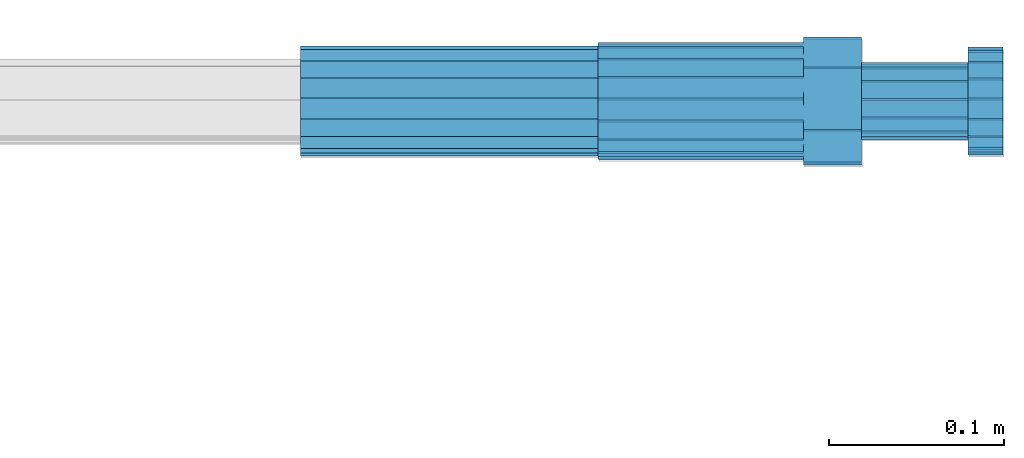
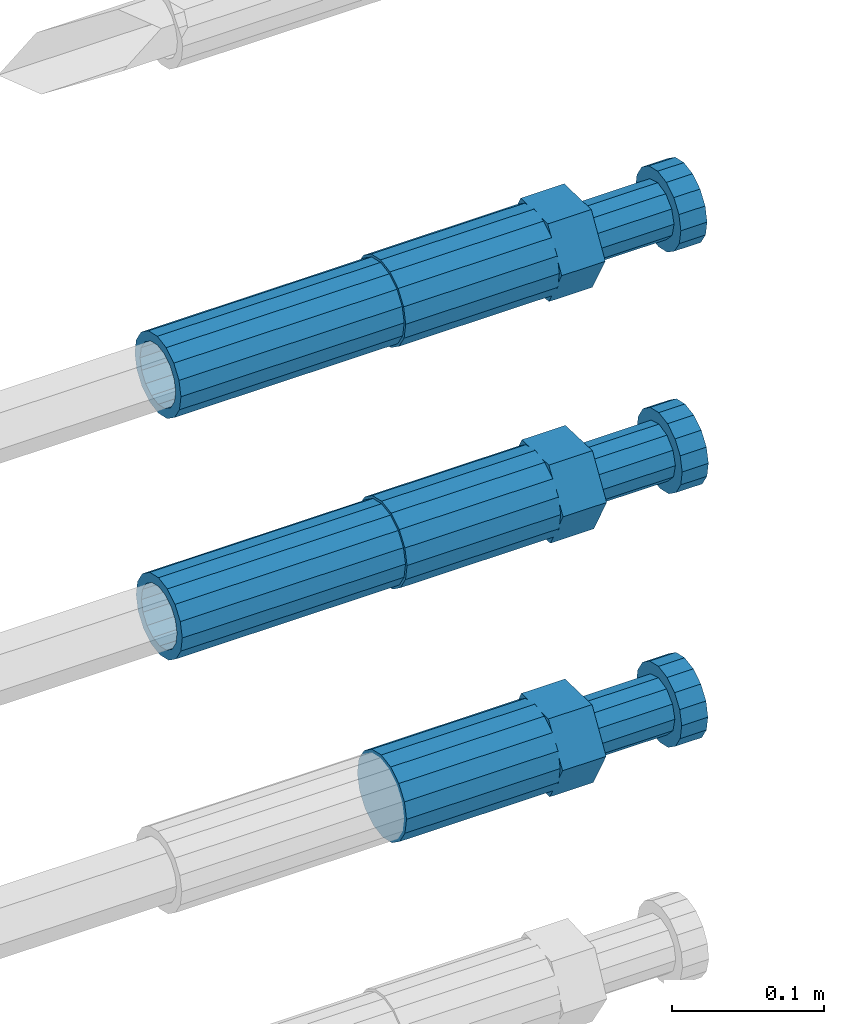
# One storey, part 110 of 177: 5 beams.
"""IFC2X3 building model written with IfcOpenShell, lengths in millimetres."""

from ifc_helpers import new_model, si_unit, frame, origin_with_axes, place, context, subcontext, project, spatial, faceted_brep, material, type_object, element, save


model = new_model("IFC2X3")

# Units and contexts
model_context_1 = context("Model", 3, precision=1e-05, world=origin_with_axes())
model_context_2 = context("Model", 3, precision=1e-05, world=origin_with_axes())
body_context = subcontext(model_context_2, "Body", "Model", "MODEL_VIEW")
ifc_project = project(units=[si_unit("LENGTHUNIT", "METRE", prefix="MILLI"), si_unit("AREAUNIT", "SQUARE_METRE"), si_unit("VOLUMEUNIT", "CUBIC_METRE"), si_unit("MASSUNIT", "GRAM", prefix="KILO"), si_unit("TIMEUNIT", "SECOND"), si_unit("PLANEANGLEUNIT", "RADIAN"), si_unit("SOLIDANGLEUNIT", "STERADIAN"), si_unit("THERMODYNAMICTEMPERATUREUNIT", "DEGREE_CELSIUS"), si_unit("LUMINOUSINTENSITYUNIT", "LUMEN")], contexts=[model_context_1])

# Site, building, storey
site_placement = place(None, origin_with_axes())
site = spatial("IfcSite", under=ifc_project, at=site_placement, CompositionType="ELEMENT")
building_placement = place(site_placement, origin_with_axes())
building = spatial("IfcBuilding", under=site, at=building_placement, Name="Undefined", CompositionType="ELEMENT")
storey_placement = place(building_placement, origin_with_axes())
storey = spatial("IfcBuildingStorey", under=building, at=storey_placement, Name="Undefined", CompositionType="ELEMENT", Elevation=0.0)

# Beams
ifc_material = material(Name="STEEL/S275")
beam_type_1 = type_object("IfcBeamType", PredefinedType="NOTDEFINED")
beam_1_placement = place(storey_placement, frame((2039349.01982224, 6206398.98702464, 20268.9865982332), z_axis=(0.0, -0.0326318619986999, -0.999467438980629), x_axis=(1.0, 0.0, 0.0)))
element("IfcBeam", 1, at=beam_1_placement, inside=storey, type_object=beam_type_1, material=ifc_material, Name="AG40N", context=body_context, shape_type="Brep", body=[
    faceted_brep([(0.0, -23.5000000001164, -9.31322574615479e-10), (0.0, -21.7111690140155, 8.99306066054851), (170.0, -21.7111690140155, 8.99306066054851), (170.0, -23.5, 0.0), (0.0, -16.6170093578839, 16.6170093575493), (170.0, -16.6170093578839, 16.6170093575493), (0.0, -8.99306066057943, 21.7111690137535), (170.0, -8.99306066057943, 21.7111690137535), (0.0, 1.16415321826935e-10, 23.5), (170.0, 0.0, 23.5), (0.0, 8.99306066057943, 21.7111690137535), (170.0, 8.99306066057943, 21.7111690137535), (0.0, 16.6170093578839, 16.6170093575493), (170.0, 16.6170093578839, 16.6170093575493), (0.0, 21.7111690140155, 8.99306066054851), (170.0, 21.7111690140155, 8.99306066054851), (0.0, 23.5000000001164, -9.31322574615479e-10), (170.0, 23.5, 0.0), (0.0, 21.7111690140155, -8.99306066054851), (170.0, 21.7111690140155, -8.99306066054851), (0.0, 16.6170093578839, -16.6170093575493), (170.0, 16.6170093578839, -16.6170093575493), (0.0, 8.99306066057943, -21.7111690137535), (170.0, 8.99306066057943, -21.7111690137535), (0.0, 1.16415321826935e-10, -23.5000000009313), (170.0, 0.0, -23.5), (0.0, -8.99306066057943, -21.7111690137535), (170.0, -8.99306066057943, -21.7111690137535), (0.0, -16.6170093578839, -16.6170093575493), (170.0, -16.6170093578839, -16.6170093575493), (0.0, -21.7111690140155, -8.99306066054851), (170.0, -21.7111690140155, -8.99306066054851), (0.0, -30.5, 0.0), (0.0, -28.1783257415937, -11.6718446873128), (170.0, -28.1783257415937, -11.6718446873128), (170.0, -30.5, 0.0), (0.0, -21.5667568261888, -21.5667568258941), (170.0, -21.5667568261888, -21.5667568258941), (0.0, -11.6718446871346, -28.1783257415518), (170.0, -11.6718446871346, -28.1783257415518), (0.0, 0.0, -30.5), (170.0, 0.0, -30.5), (0.0, 11.6718446871346, -28.1783257415518), (170.0, 11.6718446871346, -28.1783257415518), (0.0, 21.5667568261888, -21.5667568258941), (170.0, 21.5667568261888, -21.5667568258941), (0.0, 28.1783257415937, -11.6718446873128), (170.0, 28.1783257415937, -11.6718446873128), (0.0, 30.5, 0.0), (170.0, 30.5, 0.0), (0.0, 28.1783257415937, 11.6718446873128), (170.0, 28.1783257415937, 11.6718446873128), (0.0, 21.5667568261888, 21.5667568258941), (170.0, 21.5667568261888, 21.5667568258941), (0.0, 11.6718446871346, 28.1783257415518), (170.0, 11.6718446871346, 28.1783257415518), (0.0, 0.0, 30.5), (170.0, 0.0, 30.5), (0.0, -11.6718446871346, 28.1783257415518), (170.0, -11.6718446871346, 28.1783257415518), (0.0, -21.5667568261888, 21.5667568258941), (170.0, -21.5667568261888, 21.5667568258941), (0.0, -28.1783257415937, 11.6718446873128), (170.0, -28.1783257415937, 11.6718446873128)], [[[0, 1, 2, 3]], [[1, 4, 5, 2]], [[4, 6, 7, 5]], [[6, 8, 9, 7]], [[8, 10, 11, 9]], [[10, 12, 13, 11]], [[12, 14, 15, 13]], [[14, 16, 17, 15]], [[16, 18, 19, 17]], [[18, 20, 21, 19]], [[20, 22, 23, 21]], [[22, 24, 25, 23]], [[24, 26, 27, 25]], [[26, 28, 29, 27]], [[28, 30, 31, 29]], [[30, 0, 3, 31]], [[32, 33, 34, 35]], [[33, 36, 37, 34]], [[36, 38, 39, 37]], [[38, 40, 41, 39]], [[40, 42, 43, 41]], [[42, 44, 45, 43]], [[44, 46, 47, 45]], [[46, 48, 49, 47]], [[48, 50, 51, 49]], [[50, 52, 53, 51]], [[52, 54, 55, 53]], [[54, 56, 57, 55]], [[56, 58, 59, 57]], [[58, 60, 61, 59]], [[60, 62, 63, 61]], [[62, 32, 35, 63]], [[37, 39, 41, 43, 45, 47, 49, 51, 53, 55, 57, 59, 61, 63, 35, 34], [5, 7, 9, 11, 13, 15, 17, 19, 21, 23, 25, 27, 29, 31, 3, 2]], [[62, 60, 58, 56, 54, 52, 50, 48, 46, 44, 42, 40, 38, 36, 33, 32], [30, 28, 26, 24, 22, 20, 18, 16, 14, 12, 10, 8, 6, 4, 1, 0]]]),
])
beam_2_placement = place(storey_placement, frame((2039349.01982224, 6206400.75643557, 20462.4006247646), z_axis=(0.0, -0.0239087310098113, -0.999714145434334), x_axis=(1.0, 0.0, 0.0)))
element("IfcBeam", 2, at=beam_2_placement, inside=storey, type_object=beam_type_1, material=ifc_material, Name="AG40N", context=body_context, shape_type="Brep", body=[
    faceted_brep([(0.0, -23.5000000001164, -9.31322574615479e-10), (0.0, -21.7111690140155, 8.99306066054851), (170.0, -21.7111690140155, 8.99306066054851), (170.0, -23.5, 0.0), (0.0, -16.6170093578839, 16.6170093575493), (170.0, -16.6170093578839, 16.6170093575493), (0.0, -8.99306066057943, 21.7111690137535), (170.0, -8.99306066057943, 21.7111690137535), (0.0, 1.16415321826935e-10, 23.5), (170.0, 0.0, 23.5), (0.0, 8.99306066057943, 21.7111690137535), (170.0, 8.99306066057943, 21.7111690137535), (0.0, 16.6170093578839, 16.6170093575493), (170.0, 16.6170093578839, 16.6170093575493), (0.0, 21.7111690140155, 8.99306066054851), (170.0, 21.7111690140155, 8.99306066054851), (0.0, 23.5000000001164, -9.31322574615479e-10), (170.0, 23.5, 0.0), (0.0, 21.7111690140155, -8.99306066054851), (170.0, 21.7111690140155, -8.99306066054851), (0.0, 16.6170093578839, -16.6170093575493), (170.0, 16.6170093578839, -16.6170093575493), (0.0, 8.99306066057943, -21.7111690137535), (170.0, 8.99306066057943, -21.7111690137535), (0.0, 1.16415321826935e-10, -23.5000000009313), (170.0, 0.0, -23.5), (0.0, -8.99306066057943, -21.7111690137535), (170.0, -8.99306066057943, -21.7111690137535), (0.0, -16.6170093578839, -16.6170093575493), (170.0, -16.6170093578839, -16.6170093575493), (0.0, -21.7111690140155, -8.99306066054851), (170.0, -21.7111690140155, -8.99306066054851), (0.0, -30.5, 0.0), (0.0, -28.1783257415937, -11.6718446873128), (170.0, -28.1783257415937, -11.6718446873128), (170.0, -30.5, 0.0), (0.0, -21.5667568261888, -21.5667568258941), (170.0, -21.5667568261888, -21.5667568258941), (0.0, -11.6718446871346, -28.1783257415518), (170.0, -11.6718446871346, -28.1783257415518), (0.0, 0.0, -30.5), (170.0, 0.0, -30.5), (0.0, 11.6718446871346, -28.1783257415518), (170.0, 11.6718446871346, -28.1783257415518), (0.0, 21.5667568261888, -21.5667568258941), (170.0, 21.5667568261888, -21.5667568258941), (0.0, 28.1783257415937, -11.6718446873128), (170.0, 28.1783257415937, -11.6718446873128), (0.0, 30.5, 0.0), (170.0, 30.5, 0.0), (0.0, 28.1783257415937, 11.6718446873128), (170.0, 28.1783257415937, 11.6718446873128), (0.0, 21.5667568261888, 21.5667568258941), (170.0, 21.5667568261888, 21.5667568258941), (0.0, 11.6718446871346, 28.1783257415518), (170.0, 11.6718446871346, 28.1783257415518), (0.0, 0.0, 30.5), (170.0, 0.0, 30.5), (0.0, -11.6718446871346, 28.1783257415518), (170.0, -11.6718446871346, 28.1783257415518), (0.0, -21.5667568261888, 21.5667568258941), (170.0, -21.5667568261888, 21.5667568258941), (0.0, -28.1783257415937, 11.6718446873128), (170.0, -28.1783257415937, 11.6718446873128)], [[[0, 1, 2, 3]], [[1, 4, 5, 2]], [[4, 6, 7, 5]], [[6, 8, 9, 7]], [[8, 10, 11, 9]], [[10, 12, 13, 11]], [[12, 14, 15, 13]], [[14, 16, 17, 15]], [[16, 18, 19, 17]], [[18, 20, 21, 19]], [[20, 22, 23, 21]], [[22, 24, 25, 23]], [[24, 26, 27, 25]], [[26, 28, 29, 27]], [[28, 30, 31, 29]], [[30, 0, 3, 31]], [[32, 33, 34, 35]], [[33, 36, 37, 34]], [[36, 38, 39, 37]], [[38, 40, 41, 39]], [[40, 42, 43, 41]], [[42, 44, 45, 43]], [[44, 46, 47, 45]], [[46, 48, 49, 47]], [[48, 50, 51, 49]], [[50, 52, 53, 51]], [[52, 54, 55, 53]], [[54, 56, 57, 55]], [[56, 58, 59, 57]], [[58, 60, 61, 59]], [[60, 62, 63, 61]], [[62, 32, 35, 63]], [[37, 39, 41, 43, 45, 47, 49, 51, 53, 55, 57, 59, 61, 63, 35, 34], [5, 7, 9, 11, 13, 15, 17, 19, 21, 23, 25, 27, 29, 31, 3, 2]], [[62, 60, 58, 56, 54, 52, 50, 48, 46, 44, 42, 40, 38, 36, 33, 32], [30, 28, 26, 24, 22, 20, 18, 16, 14, 12, 10, 8, 6, 4, 1, 0]]]),
])
beam_type_2 = type_object("IfcBeamType", Name="ROD65", PredefinedType="NOTDEFINED")
beam_3_placement = place(storey_placement, frame((2039519.01982224, 6206399.65861379, 20064.378419571), z_axis=(0.0, -0.0273982399934902, -0.999624597759208), x_axis=(1.0, 0.0, 0.0)))
element("IfcBeam", 3, at=beam_3_placement, inside=storey, type_object=beam_type_2, material=ifc_material, Name="AGB40", ObjectType="ROD65", context=body_context, shape_type="Brep", body=[
    faceted_brep([(117.0, 8.17543110251427, 30.873805644922), (117.0, 17.8250000001863, 30.873805644922), (117.0, 22.0056958701462, 23.6326279877685), (117.0, 12.4372115517035, 30.0260848065373), (117.0, -17.8250000001863, 30.873805644922), (150.200000000186, -17.8250000001863, 30.873805644922), (150.200000000186, 17.8250000001863, 30.873805644922), (117.0, -8.17543110251427, 30.873805644922), (117.0, -12.4372115517035, 30.0260848065373), (117.0, -22.0056958701462, 23.6326279877685), (117.0, -35.6500000003725, 0.0), (150.200000000186, -35.6500000003725, 0.0), (117.0, -30.8443150008097, 8.32369058486074), (117.0, -32.5, 0.0), (117.0, -30.8443150008097, -8.32369058462791), (117.0, -17.8250000001863, -30.873805644922), (150.200000000186, -17.8250000001863, -30.873805644922), (117.0, -22.0056958701462, -23.6326279877685), (117.0, -12.4372115517035, -30.0260848065373), (117.0, -8.17543110251427, -30.873805644922), (117.0, 17.8250000001863, -30.873805644922), (150.200000000186, 17.8250000001863, -30.873805644922), (117.0, 8.17543110251427, -30.873805644922), (117.0, 22.0056958701462, -23.6326279877685), (117.0, 12.4372115517035, -30.0260848065373), (117.0, 35.6500000003725, 0.0), (150.200000000186, 35.6500000003725, 0.0), (117.0, 30.8443150008097, -8.32369058486074), (117.0, 30.8443150008097, 8.32369058462791), (117.0, 32.5, 0.0), (0.0, -22.9809703892097, 22.9809703885621), (0.0, -30.0260848058388, 12.4372115518636), (117.0, -30.0260848067701, 12.4372115519363), (117.0, -22.9809703882784, 22.9809703885112), (-2.3283064365387e-10, 22.9809703892097, -22.9809703885639), (-4.65661287307739e-10, 30.0260848077014, -12.4372115518672), (117.0, 30.0260848067701, -12.4372115519363), (117.0, 22.9809703882784, -22.9809703885112), (-2.3283064365387e-10, -30.0260848067701, -12.4372115518672), (-2.3283064365387e-10, -22.9809703892097, -22.9809703885621), (117.0, -22.9809703882784, -22.9809703885112), (117.0, -30.0260848067701, -12.4372115519363), (-2.3283064365387e-10, -12.4372115507722, 30.0260848066137), (-2.3283064365387e-10, 9.31322574615479e-10, 32.4999999999982), (-2.3283064365387e-10, 12.4372115526348, 30.0260848066137), (0.0, 22.9809703892097, 22.9809703885621), (-2.3283064365387e-10, 30.0260848077014, 12.4372115518636), (-2.3283064365387e-10, 32.5, 0.0), (-2.3283064365387e-10, 12.4372115526348, -30.0260848066173), (-2.3283064365387e-10, 9.31322574615479e-10, -32.5), (-2.3283064365387e-10, -12.4372115517035, -30.0260848066173), (-4.65661287307739e-10, -32.4999999990687, -1.81898940354586e-12), (117.0, 22.9809703882784, 22.9809703885112), (117.0, 30.0260848067701, 12.4372115519363), (117.0, 0.0, -32.5), (117.0, 0.0, 32.5), (150.200000000186, 10.5, -18.1865334794857), (150.200000000186, 0.0, -21.0), (150.200000000186, -10.5, -18.1865334794857), (150.200000000186, -18.18653347902, -10.5), (150.200000000186, -21.0, 0.0), (150.200000000186, -18.18653347902, 10.5), (150.200000000186, -10.5, 18.1865334794857), (150.200000000186, 0.0, 21.0), (150.200000000186, 10.5, 18.1865334794857), (150.200000000186, 18.18653347902, 10.5), (150.200000000186, 21.0, 0.0), (150.200000000186, 18.18653347902, -10.5), (210.980000000447, -18.18653347902, 10.5), (210.980000000447, -21.0, 0.0), (210.980000000447, -10.5, 18.1865334794857), (210.980000000447, 0.0, 21.0), (210.980000000447, 10.5, 18.1865334794857), (210.980000000447, 18.18653347902, 10.5), (210.980000000447, 21.0, 0.0), (210.980000000447, 18.18653347902, -10.5), (210.980000000447, 10.5, -18.1865334794857), (210.980000000447, 0.0, -21.0), (210.980000000447, -10.5, -18.1865334794857), (210.980000000447, -18.18653347902, -10.5), (211.001368442696, -27.7269937992096, -11.491116326768), (211.003082550167, -21.2238094303757, -21.223815418547), (231.002518367059, -21.2131944671273, -21.2132004550658), (231.000804259587, -27.7163788359612, -11.4805013632867), (211.001368440451, -11.4911085031927, -27.7269970395137), (231.000804257343, -11.4804935399443, -27.7163820760325), (210.996487071217, -0.0106065049767494, -30.0106107392348), (230.995922888109, 8.45827162265778e-06, -29.9999957757536), (210.989181586672, 11.46989420522, -27.7269970329944), (230.988617403564, 11.4805091684684, -27.7163820695132), (210.980564180623, 21.2025914648548, -21.2238154064398), (230.979999997515, 21.2132064281031, -21.2132004429586), (210.971946775022, 27.7057703435421, -11.4911163107026), (230.971382591913, 27.7163853067905, -11.4805013472214), (210.96464129175, 29.9893808094785, -0.0106149562634528), (230.964077108642, 29.9999957727268, 7.21774995326996e-09), (210.959759924415, 27.7057638689876, 11.4698863970116), (230.959195741307, 27.7163788322359, 11.4805013604928), (210.958045816944, 21.2025795001537, 21.2025854887906), (230.957481633835, 21.213194463402, 21.2132004522718), (210.95975992666, 11.4698785729706, 27.7057671097573), (230.959195743551, 11.480493536219, 27.7163820732385), (210.964641295894, -0.010623425245285, 29.9893808094785), (230.964077112785, -8.46199691295624e-06, 29.9999957729597), (210.971946780439, -11.4911241354421, 27.705767103238), (230.97138259733, -11.4805091721937, 27.7163820667192), (210.980564186488, -21.2238213950768, 21.2025854766835), (230.980000003379, -21.2132064318284, 21.2132004401647), (210.989181592089, -27.7270002737641, 11.4698863809463), (230.988617408981, -27.7163853105158, 11.4805013444275), (210.996487075361, -30.0106107397005, -0.0106149734929204), (230.995922892253, -29.9999957764521, -1.00117176771164e-08)], [[[0, 1, 2, 3]], [[4, 5, 6, 1, 0, 7]], [[4, 7, 8, 9]], [[10, 11, 5, 4, 9, 12]], [[10, 12, 13, 14]], [[15, 16, 11, 10, 14, 17]], [[15, 17, 18, 19]], [[20, 21, 16, 15, 19, 22]], [[23, 20, 22, 24]], [[25, 26, 21, 20, 23, 27]], [[28, 25, 27, 29]], [[30, 31, 32, 33]], [[34, 35, 36, 37]], [[38, 39, 40, 41]], [[31, 30, 42, 43, 44, 45, 46, 47, 35, 34, 48, 49, 50, 39, 38, 51]], [[46, 45, 52, 53]], [[29, 47, 46, 53, 28]], [[27, 36, 35, 47, 29]], [[23, 37, 36, 27]], [[24, 48, 34, 37, 23]], [[22, 54, 49, 48, 24]], [[19, 54, 22]], [[18, 50, 49, 54, 19]], [[17, 40, 39, 50, 18]], [[14, 41, 40, 17]], [[13, 51, 38, 41, 14]], [[12, 32, 31, 51, 13]], [[9, 33, 32, 12]], [[8, 42, 30, 33, 9]], [[7, 55, 43, 42, 8]], [[0, 55, 7]], [[3, 44, 43, 55, 0]], [[2, 52, 45, 44, 3]], [[28, 53, 52, 2]], [[1, 6, 26, 25, 28, 2]], [[5, 11, 16, 21, 26, 6], [56, 57, 58, 59, 60, 61, 62, 63, 64, 65, 66, 67]], [[68, 61, 60, 69]], [[70, 62, 61, 68]], [[71, 63, 62, 70]], [[72, 64, 63, 71]], [[73, 65, 64, 72]], [[74, 66, 65, 73]], [[75, 67, 66, 74]], [[76, 56, 67, 75]], [[77, 57, 56, 76]], [[78, 58, 57, 77]], [[79, 59, 58, 78]], [[69, 60, 59, 79]], [[80, 81, 82, 83]], [[81, 84, 85, 82]], [[84, 86, 87, 85]], [[86, 88, 89, 87]], [[88, 90, 91, 89]], [[90, 92, 93, 91]], [[92, 94, 95, 93]], [[94, 96, 97, 95]], [[96, 98, 99, 97]], [[98, 100, 101, 99]], [[100, 102, 103, 101]], [[102, 104, 105, 103]], [[104, 106, 107, 105]], [[106, 108, 109, 107]], [[108, 110, 111, 109]], [[82, 85, 87, 89, 91, 93, 95, 97, 99, 101, 103, 105, 107, 109, 111, 83]], [[110, 80, 83, 111]], [[108, 106, 104, 102, 100, 98, 96, 94, 92, 90, 88, 86, 84, 81, 80, 110], [75, 74, 73, 72, 71, 70, 68, 69, 79, 78, 77, 76]]]),
])
beam_4_placement = place(storey_placement, frame((2039519.01982224, 6206398.9870246, 20268.9865982313), z_axis=(0.0, -0.0326318619986999, -0.999467438980629), x_axis=(1.0, 0.0, 0.0)))
element("IfcBeam", 4, at=beam_4_placement, inside=storey, type_object=beam_type_2, material=ifc_material, Name="AGB40", ObjectType="ROD65", context=body_context, shape_type="Brep", body=[
    faceted_brep([(117.0, 8.17543110251427, 30.873805644922), (117.0, 17.8250000001863, 30.873805644922), (117.0, 22.0056958701462, 23.6326279877685), (117.0, 12.4372115517035, 30.0260848065373), (117.0, -17.8250000001863, 30.873805644922), (150.200000000186, -17.8250000001863, 30.873805644922), (150.200000000186, 17.8250000001863, 30.873805644922), (117.0, -8.17543110251427, 30.873805644922), (117.0, -12.4372115517035, 30.0260848065373), (117.0, -22.0056958701462, 23.6326279877685), (117.0, -35.6500000003725, 0.0), (150.200000000186, -35.6500000003725, 0.0), (117.0, -30.8443150008097, 8.32369058486074), (117.0, -32.5, 0.0), (117.0, -30.8443150008097, -8.32369058462791), (117.0, -17.8250000001863, -30.873805644922), (150.200000000186, -17.8250000001863, -30.873805644922), (117.0, -22.0056958701462, -23.6326279877685), (117.0, -12.4372115517035, -30.0260848065373), (117.0, -8.17543110251427, -30.873805644922), (117.0, 17.8250000001863, -30.873805644922), (150.200000000186, 17.8250000001863, -30.873805644922), (117.0, 8.17543110251427, -30.873805644922), (117.0, 22.0056958701462, -23.6326279877685), (117.0, 12.4372115517035, -30.0260848065373), (117.0, 35.6500000003725, 0.0), (150.200000000186, 35.6500000003725, 0.0), (117.0, 30.8443150008097, -8.32369058486074), (117.0, 30.8443150008097, 8.32369058462791), (117.0, 32.5, 0.0), (0.0, -22.9809703892097, 22.9809703885621), (0.0, -30.0260848058388, 12.4372115518636), (117.0, -30.0260848067701, 12.4372115519363), (117.0, -22.9809703882784, 22.9809703885112), (-2.3283064365387e-10, 22.9809703892097, -22.9809703885639), (-4.65661287307739e-10, 30.0260848077014, -12.4372115518672), (117.0, 30.0260848067701, -12.4372115519363), (117.0, 22.9809703882784, -22.9809703885112), (-2.3283064365387e-10, -30.0260848067701, -12.4372115518672), (-2.3283064365387e-10, -22.9809703892097, -22.9809703885621), (117.0, -22.9809703882784, -22.9809703885112), (117.0, -30.0260848067701, -12.4372115519363), (-2.3283064365387e-10, -12.4372115507722, 30.0260848066137), (-2.3283064365387e-10, 9.31322574615479e-10, 32.4999999999982), (-2.3283064365387e-10, 12.4372115526348, 30.0260848066137), (0.0, 22.9809703892097, 22.9809703885621), (-2.3283064365387e-10, 30.0260848077014, 12.4372115518636), (-2.3283064365387e-10, 32.5, 0.0), (-2.3283064365387e-10, 12.4372115526348, -30.0260848066173), (-2.3283064365387e-10, 9.31322574615479e-10, -32.5), (-2.3283064365387e-10, -12.4372115517035, -30.0260848066173), (-4.65661287307739e-10, -32.4999999990687, -1.81898940354586e-12), (117.0, 22.9809703882784, 22.9809703885112), (117.0, 30.0260848067701, 12.4372115519363), (117.0, 0.0, -32.5), (117.0, 0.0, 32.5), (150.200000000186, 10.5, -18.1865334794857), (150.200000000186, 0.0, -21.0), (150.200000000186, -10.5, -18.1865334794857), (150.200000000186, -18.18653347902, -10.5), (150.200000000186, -21.0, 0.0), (150.200000000186, -18.18653347902, 10.5), (150.200000000186, -10.5, 18.1865334794857), (150.200000000186, 0.0, 21.0), (150.200000000186, 10.5, 18.1865334794857), (150.200000000186, 18.18653347902, 10.5), (150.200000000186, 21.0, 0.0), (150.200000000186, 18.18653347902, -10.5), (210.980000000447, -18.18653347902, 10.5), (210.980000000447, -21.0, 0.0), (210.980000000447, -10.5, 18.1865334794857), (210.980000000447, 0.0, 21.0), (210.980000000447, 10.5, 18.1865334794857), (210.980000000447, 18.18653347902, 10.5), (210.980000000447, 21.0, 0.0), (210.980000000447, 18.18653347902, -10.5), (210.980000000447, 10.5, -18.1865334794857), (210.980000000447, 0.0, -21.0), (210.980000000447, -10.5, -18.1865334794857), (210.980000000447, -18.18653347902, -10.5), (211.001368442696, -27.7269937992096, -11.491116326768), (211.003082550167, -21.2238094303757, -21.223815418547), (231.002518367059, -21.2131944671273, -21.2132004550658), (231.000804259587, -27.7163788359612, -11.4805013632867), (211.001368440451, -11.4911085031927, -27.7269970395137), (231.000804257343, -11.4804935399443, -27.7163820760325), (210.996487071217, -0.0106065049767494, -30.0106107392348), (230.995922888109, 8.45827162265778e-06, -29.9999957757536), (210.989181586672, 11.46989420522, -27.7269970329944), (230.988617403564, 11.4805091684684, -27.7163820695132), (210.980564180623, 21.2025914648548, -21.2238154064398), (230.979999997515, 21.2132064281031, -21.2132004429586), (210.971946775022, 27.7057703435421, -11.4911163107026), (230.971382591913, 27.7163853067905, -11.4805013472214), (210.96464129175, 29.9893808094785, -0.0106149562634528), (230.964077108642, 29.9999957727268, 7.21774995326996e-09), (210.959759924415, 27.7057638689876, 11.4698863970116), (230.959195741307, 27.7163788322359, 11.4805013604928), (210.958045816944, 21.2025795001537, 21.2025854887906), (230.957481633835, 21.213194463402, 21.2132004522718), (210.95975992666, 11.4698785729706, 27.7057671097573), (230.959195743551, 11.480493536219, 27.7163820732385), (210.964641295894, -0.010623425245285, 29.9893808094785), (230.964077112785, -8.46199691295624e-06, 29.9999957729597), (210.971946780439, -11.4911241354421, 27.705767103238), (230.97138259733, -11.4805091721937, 27.7163820667192), (210.980564186488, -21.2238213950768, 21.2025854766835), (230.980000003379, -21.2132064318284, 21.2132004401647), (210.989181592089, -27.7270002737641, 11.4698863809463), (230.988617408981, -27.7163853105158, 11.4805013444275), (210.996487075361, -30.0106107397005, -0.0106149734929204), (230.995922892253, -29.9999957764521, -1.00117176771164e-08)], [[[0, 1, 2, 3]], [[4, 5, 6, 1, 0, 7]], [[4, 7, 8, 9]], [[10, 11, 5, 4, 9, 12]], [[10, 12, 13, 14]], [[15, 16, 11, 10, 14, 17]], [[15, 17, 18, 19]], [[20, 21, 16, 15, 19, 22]], [[23, 20, 22, 24]], [[25, 26, 21, 20, 23, 27]], [[28, 25, 27, 29]], [[30, 31, 32, 33]], [[34, 35, 36, 37]], [[38, 39, 40, 41]], [[31, 30, 42, 43, 44, 45, 46, 47, 35, 34, 48, 49, 50, 39, 38, 51]], [[46, 45, 52, 53]], [[29, 47, 46, 53, 28]], [[27, 36, 35, 47, 29]], [[23, 37, 36, 27]], [[24, 48, 34, 37, 23]], [[22, 54, 49, 48, 24]], [[19, 54, 22]], [[18, 50, 49, 54, 19]], [[17, 40, 39, 50, 18]], [[14, 41, 40, 17]], [[13, 51, 38, 41, 14]], [[12, 32, 31, 51, 13]], [[9, 33, 32, 12]], [[8, 42, 30, 33, 9]], [[7, 55, 43, 42, 8]], [[0, 55, 7]], [[3, 44, 43, 55, 0]], [[2, 52, 45, 44, 3]], [[28, 53, 52, 2]], [[1, 6, 26, 25, 28, 2]], [[5, 11, 16, 21, 26, 6], [56, 57, 58, 59, 60, 61, 62, 63, 64, 65, 66, 67]], [[68, 61, 60, 69]], [[70, 62, 61, 68]], [[71, 63, 62, 70]], [[72, 64, 63, 71]], [[73, 65, 64, 72]], [[74, 66, 65, 73]], [[75, 67, 66, 74]], [[76, 56, 67, 75]], [[77, 57, 56, 76]], [[78, 58, 57, 77]], [[79, 59, 58, 78]], [[69, 60, 59, 79]], [[80, 81, 82, 83]], [[81, 84, 85, 82]], [[84, 86, 87, 85]], [[86, 88, 89, 87]], [[88, 90, 91, 89]], [[90, 92, 93, 91]], [[92, 94, 95, 93]], [[94, 96, 97, 95]], [[96, 98, 99, 97]], [[98, 100, 101, 99]], [[100, 102, 103, 101]], [[102, 104, 105, 103]], [[104, 106, 107, 105]], [[106, 108, 109, 107]], [[108, 110, 111, 109]], [[82, 85, 87, 89, 91, 93, 95, 97, 99, 101, 103, 105, 107, 109, 111, 83]], [[110, 80, 83, 111]], [[108, 106, 104, 102, 100, 98, 96, 94, 92, 90, 88, 86, 84, 81, 80, 110], [75, 74, 73, 72, 71, 70, 68, 69, 79, 78, 77, 76]]]),
])
beam_5_placement = place(storey_placement, frame((2039519.01982224, 6206400.75643553, 20462.400624763), z_axis=(0.0, -0.0239087310098113, -0.999714145434334), x_axis=(1.0, 0.0, 0.0)))
element("IfcBeam", 5, at=beam_5_placement, inside=storey, type_object=beam_type_2, material=ifc_material, Name="AGB40", ObjectType="ROD65", context=body_context, shape_type="Brep", body=[
    faceted_brep([(117.0, 8.17543110251427, 30.873805644922), (117.0, 17.8250000001863, 30.873805644922), (117.0, 22.0056958701462, 23.6326279877685), (117.0, 12.4372115517035, 30.0260848065373), (117.0, -17.8250000001863, 30.873805644922), (150.200000000186, -17.8250000001863, 30.873805644922), (150.200000000186, 17.8250000001863, 30.873805644922), (117.0, -8.17543110251427, 30.873805644922), (117.0, -12.4372115517035, 30.0260848065373), (117.0, -22.0056958701462, 23.6326279877685), (117.0, -35.6500000003725, 0.0), (150.200000000186, -35.6500000003725, 0.0), (117.0, -30.8443150008097, 8.32369058486074), (117.0, -32.5, 0.0), (117.0, -30.8443150008097, -8.32369058462791), (117.0, -17.8250000001863, -30.873805644922), (150.200000000186, -17.8250000001863, -30.873805644922), (117.0, -22.0056958701462, -23.6326279877685), (117.0, -12.4372115517035, -30.0260848065373), (117.0, -8.17543110251427, -30.873805644922), (117.0, 17.8250000001863, -30.873805644922), (150.200000000186, 17.8250000001863, -30.873805644922), (117.0, 8.17543110251427, -30.873805644922), (117.0, 22.0056958701462, -23.6326279877685), (117.0, 12.4372115517035, -30.0260848065373), (117.0, 35.6500000003725, 0.0), (150.200000000186, 35.6500000003725, 0.0), (117.0, 30.8443150008097, -8.32369058486074), (117.0, 30.8443150008097, 8.32369058462791), (117.0, 32.5, 0.0), (0.0, -22.9809703892097, 22.9809703885621), (0.0, -30.0260848058388, 12.4372115518636), (117.0, -30.0260848067701, 12.4372115519363), (117.0, -22.9809703882784, 22.9809703885112), (-2.3283064365387e-10, 22.9809703892097, -22.9809703885639), (-4.65661287307739e-10, 30.0260848077014, -12.4372115518672), (117.0, 30.0260848067701, -12.4372115519363), (117.0, 22.9809703882784, -22.9809703885112), (-2.3283064365387e-10, -30.0260848067701, -12.4372115518672), (-2.3283064365387e-10, -22.9809703892097, -22.9809703885621), (117.0, -22.9809703882784, -22.9809703885112), (117.0, -30.0260848067701, -12.4372115519363), (-2.3283064365387e-10, -12.4372115507722, 30.0260848066137), (-2.3283064365387e-10, 9.31322574615479e-10, 32.4999999999982), (-2.3283064365387e-10, 12.4372115526348, 30.0260848066137), (0.0, 22.9809703892097, 22.9809703885621), (-2.3283064365387e-10, 30.0260848077014, 12.4372115518636), (-2.3283064365387e-10, 32.5, 0.0), (-2.3283064365387e-10, 12.4372115526348, -30.0260848066173), (-2.3283064365387e-10, 9.31322574615479e-10, -32.5), (-2.3283064365387e-10, -12.4372115517035, -30.0260848066173), (-4.65661287307739e-10, -32.4999999990687, -1.81898940354586e-12), (117.0, 22.9809703882784, 22.9809703885112), (117.0, 30.0260848067701, 12.4372115519363), (117.0, 0.0, -32.5), (117.0, 0.0, 32.5), (150.200000000186, 10.5, -18.1865334794857), (150.200000000186, 0.0, -21.0), (150.200000000186, -10.5, -18.1865334794857), (150.200000000186, -18.18653347902, -10.5), (150.200000000186, -21.0, 0.0), (150.200000000186, -18.18653347902, 10.5), (150.200000000186, -10.5, 18.1865334794857), (150.200000000186, 0.0, 21.0), (150.200000000186, 10.5, 18.1865334794857), (150.200000000186, 18.18653347902, 10.5), (150.200000000186, 21.0, 0.0), (150.200000000186, 18.18653347902, -10.5), (210.980000000447, -18.18653347902, 10.5), (210.980000000447, -21.0, 0.0), (210.980000000447, -10.5, 18.1865334794857), (210.980000000447, 0.0, 21.0), (210.980000000447, 10.5, 18.1865334794857), (210.980000000447, 18.18653347902, 10.5), (210.980000000447, 21.0, 0.0), (210.980000000447, 18.18653347902, -10.5), (210.980000000447, 10.5, -18.1865334794857), (210.980000000447, 0.0, -21.0), (210.980000000447, -10.5, -18.1865334794857), (210.980000000447, -18.18653347902, -10.5), (211.001368442696, -27.7269937992096, -11.491116326768), (211.003082550167, -21.2238094303757, -21.223815418547), (231.002518367059, -21.2131944671273, -21.2132004550658), (231.000804259587, -27.7163788359612, -11.4805013632867), (211.001368440451, -11.4911085031927, -27.7269970395137), (231.000804257343, -11.4804935399443, -27.7163820760325), (210.996487071217, -0.0106065049767494, -30.0106107392348), (230.995922888109, 8.45827162265778e-06, -29.9999957757536), (210.989181586672, 11.46989420522, -27.7269970329944), (230.988617403564, 11.4805091684684, -27.7163820695132), (210.980564180623, 21.2025914648548, -21.2238154064398), (230.979999997515, 21.2132064281031, -21.2132004429586), (210.971946775022, 27.7057703435421, -11.4911163107026), (230.971382591913, 27.7163853067905, -11.4805013472214), (210.96464129175, 29.9893808094785, -0.0106149562634528), (230.964077108642, 29.9999957727268, 7.21774995326996e-09), (210.959759924415, 27.7057638689876, 11.4698863970116), (230.959195741307, 27.7163788322359, 11.4805013604928), (210.958045816944, 21.2025795001537, 21.2025854887906), (230.957481633835, 21.213194463402, 21.2132004522718), (210.95975992666, 11.4698785729706, 27.7057671097573), (230.959195743551, 11.480493536219, 27.7163820732385), (210.964641295894, -0.010623425245285, 29.9893808094785), (230.964077112785, -8.46199691295624e-06, 29.9999957729597), (210.971946780439, -11.4911241354421, 27.705767103238), (230.97138259733, -11.4805091721937, 27.7163820667192), (210.980564186488, -21.2238213950768, 21.2025854766835), (230.980000003379, -21.2132064318284, 21.2132004401647), (210.989181592089, -27.7270002737641, 11.4698863809463), (230.988617408981, -27.7163853105158, 11.4805013444275), (210.996487075361, -30.0106107397005, -0.0106149734929204), (230.995922892253, -29.9999957764521, -1.00117176771164e-08)], [[[0, 1, 2, 3]], [[4, 5, 6, 1, 0, 7]], [[4, 7, 8, 9]], [[10, 11, 5, 4, 9, 12]], [[10, 12, 13, 14]], [[15, 16, 11, 10, 14, 17]], [[15, 17, 18, 19]], [[20, 21, 16, 15, 19, 22]], [[23, 20, 22, 24]], [[25, 26, 21, 20, 23, 27]], [[28, 25, 27, 29]], [[30, 31, 32, 33]], [[34, 35, 36, 37]], [[38, 39, 40, 41]], [[31, 30, 42, 43, 44, 45, 46, 47, 35, 34, 48, 49, 50, 39, 38, 51]], [[46, 45, 52, 53]], [[29, 47, 46, 53, 28]], [[27, 36, 35, 47, 29]], [[23, 37, 36, 27]], [[24, 48, 34, 37, 23]], [[22, 54, 49, 48, 24]], [[19, 54, 22]], [[18, 50, 49, 54, 19]], [[17, 40, 39, 50, 18]], [[14, 41, 40, 17]], [[13, 51, 38, 41, 14]], [[12, 32, 31, 51, 13]], [[9, 33, 32, 12]], [[8, 42, 30, 33, 9]], [[7, 55, 43, 42, 8]], [[0, 55, 7]], [[3, 44, 43, 55, 0]], [[2, 52, 45, 44, 3]], [[28, 53, 52, 2]], [[1, 6, 26, 25, 28, 2]], [[5, 11, 16, 21, 26, 6], [56, 57, 58, 59, 60, 61, 62, 63, 64, 65, 66, 67]], [[68, 61, 60, 69]], [[70, 62, 61, 68]], [[71, 63, 62, 70]], [[72, 64, 63, 71]], [[73, 65, 64, 72]], [[74, 66, 65, 73]], [[75, 67, 66, 74]], [[76, 56, 67, 75]], [[77, 57, 56, 76]], [[78, 58, 57, 77]], [[79, 59, 58, 78]], [[69, 60, 59, 79]], [[80, 81, 82, 83]], [[81, 84, 85, 82]], [[84, 86, 87, 85]], [[86, 88, 89, 87]], [[88, 90, 91, 89]], [[90, 92, 93, 91]], [[92, 94, 95, 93]], [[94, 96, 97, 95]], [[96, 98, 99, 97]], [[98, 100, 101, 99]], [[100, 102, 103, 101]], [[102, 104, 105, 103]], [[104, 106, 107, 105]], [[106, 108, 109, 107]], [[108, 110, 111, 109]], [[82, 85, 87, 89, 91, 93, 95, 97, 99, 101, 103, 105, 107, 109, 111, 83]], [[110, 80, 83, 111]], [[108, 106, 104, 102, 100, 98, 96, 94, 92, 90, 88, 86, 84, 81, 80, 110], [75, 74, 73, 72, 71, 70, 68, 69, 79, 78, 77, 76]]]),
])

save(model, "model.ifc")
